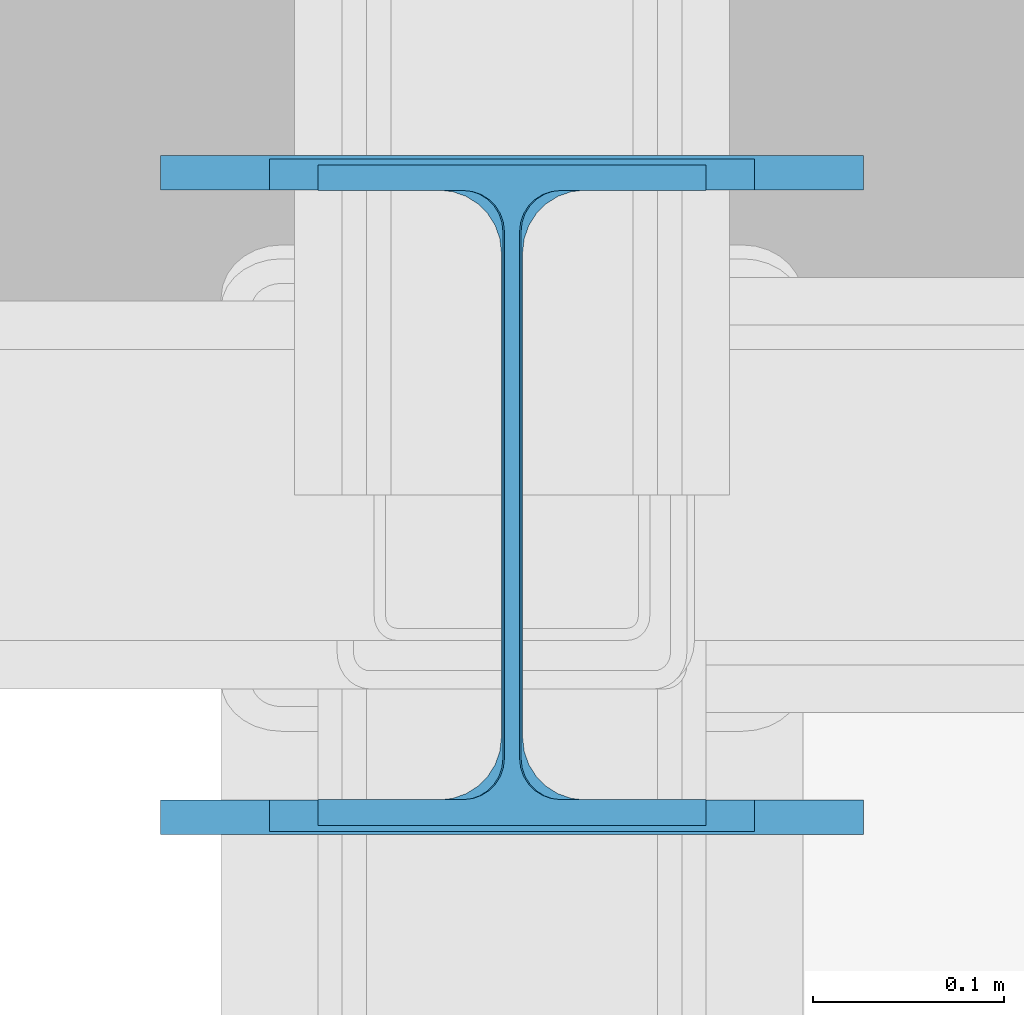
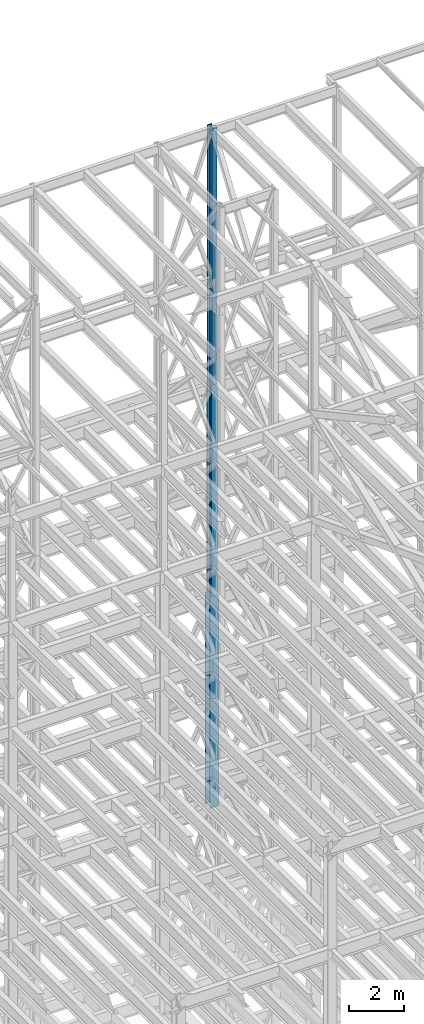
# One storey, part 108 of 150: 3 columns.
"""IFC2X3 building model written with IfcOpenShell, lengths in millimetres."""

from ifc_helpers import new_model, si_unit, frame, origin_with_axes, origin_2d_with_axis, place, context, subcontext, project, spatial, i_section, extrude, material, type_object, element, save


model = new_model("IFC2X3")

# Units and contexts
model_context = context("Model", 3, precision=1e-05, world=origin_with_axes())
body_context = subcontext(model_context, "Body", "Model", "MODEL_VIEW")
ifc_project = project(units=[si_unit("LENGTHUNIT", "METRE", prefix="MILLI"), si_unit("AREAUNIT", "SQUARE_METRE"), si_unit("VOLUMEUNIT", "CUBIC_METRE"), si_unit("MASSUNIT", "GRAM", prefix="KILO"), si_unit("TIMEUNIT", "SECOND"), si_unit("PLANEANGLEUNIT", "RADIAN"), si_unit("SOLIDANGLEUNIT", "STERADIAN"), si_unit("THERMODYNAMICTEMPERATUREUNIT", "DEGREE_CELSIUS"), si_unit("LUMINOUSINTENSITYUNIT", "LUMEN")], contexts=[model_context])

# Site, building, storey
site_placement = place(None, origin_with_axes())
site = spatial("IfcSite", under=ifc_project, at=site_placement, CompositionType="ELEMENT")
building_placement = place(site_placement, origin_with_axes())
building = spatial("IfcBuilding", under=site, at=building_placement, Name="Undefined", CompositionType="ELEMENT")
storey_placement = place(building_placement, origin_with_axes())
storey = spatial("IfcBuildingStorey", under=building, at=storey_placement, Name="Undefined", CompositionType="ELEMENT", Elevation=0.0)

# Columns
ifc_material = material(Name="STEEL/A992")
column_type_1 = type_object("IfcColumnType", Name="W14X43", PredefinedType="NOTDEFINED")
column_1_placement = place(storey_placement, frame((76923.9, 31877.0, 54483.0), z_axis=(0.0, 0.0, 1.0), x_axis=(1.0, 0.0, 0.0)))
element("IfcColumn", 1, at=column_1_placement, inside=storey, type_object=column_type_1, material=ifc_material, Name="COLUMN", ObjectType="W14X43", context=body_context, shape_type="SweptSolid", body=[
    extrude(i_section(OverallWidth=203.2, OverallDepth=346.075, WebThickness=7.9375, FlangeThickness=13.462, FilletRadius=21.4629, at=origin_2d_with_axis()), frame((0.0, 0.0, 11429.998857), z_axis=(0.0, 0.0, -1.0), x_axis=(-1.0, 0.0, 0.0)), (0.0, 0.0, 1.0), 11429.998857),
])
column_type_2 = type_object("IfcColumnType", Name="W14X61", PredefinedType="NOTDEFINED")
column_2_placement = place(storey_placement, frame((76923.9, 31877.0, 45034.2), z_axis=(0.0, 0.0, 1.0), x_axis=(1.0, 0.0, 0.0)))
element("IfcColumn", 2, at=column_2_placement, inside=storey, type_object=column_type_2, material=ifc_material, Name="COLUMN", ObjectType="W14X61", context=body_context, shape_type="SweptSolid", body=[
    extrude(i_section(OverallWidth=254.0, OverallDepth=352.425, WebThickness=9.5249, FlangeThickness=16.383, FilletRadius=21.717, at=origin_2d_with_axis()), frame((0.0, 0.0, 9448.8), z_axis=(0.0, 0.0, -1.0), x_axis=(-1.0, 0.0, 0.0)), (0.0, 0.0, 1.0), 9448.8),
])
column_type_3 = type_object("IfcColumnType", Name="W14X90", PredefinedType="NOTDEFINED")
column_3_placement = place(storey_placement, frame((76923.9, 31877.0, 35585.4), z_axis=(0.0, 0.0, 1.0), x_axis=(1.0, 0.0, 0.0)))
element("IfcColumn", 3, at=column_3_placement, inside=storey, type_object=column_type_3, material=ifc_material, Name="COLUMN", ObjectType="W14X90", context=body_context, shape_type="SweptSolid", body=[
    extrude(i_section(OverallWidth=368.3, OverallDepth=355.6, WebThickness=11.1125, FlangeThickness=18.034, FilletRadius=32.7659, at=origin_2d_with_axis()), frame((0.0, 0.0, 9448.8), z_axis=(0.0, 0.0, -1.0), x_axis=(-1.0, 0.0, 0.0)), (0.0, 0.0, 1.0), 9448.8),
])

save(model, "model.ifc")
